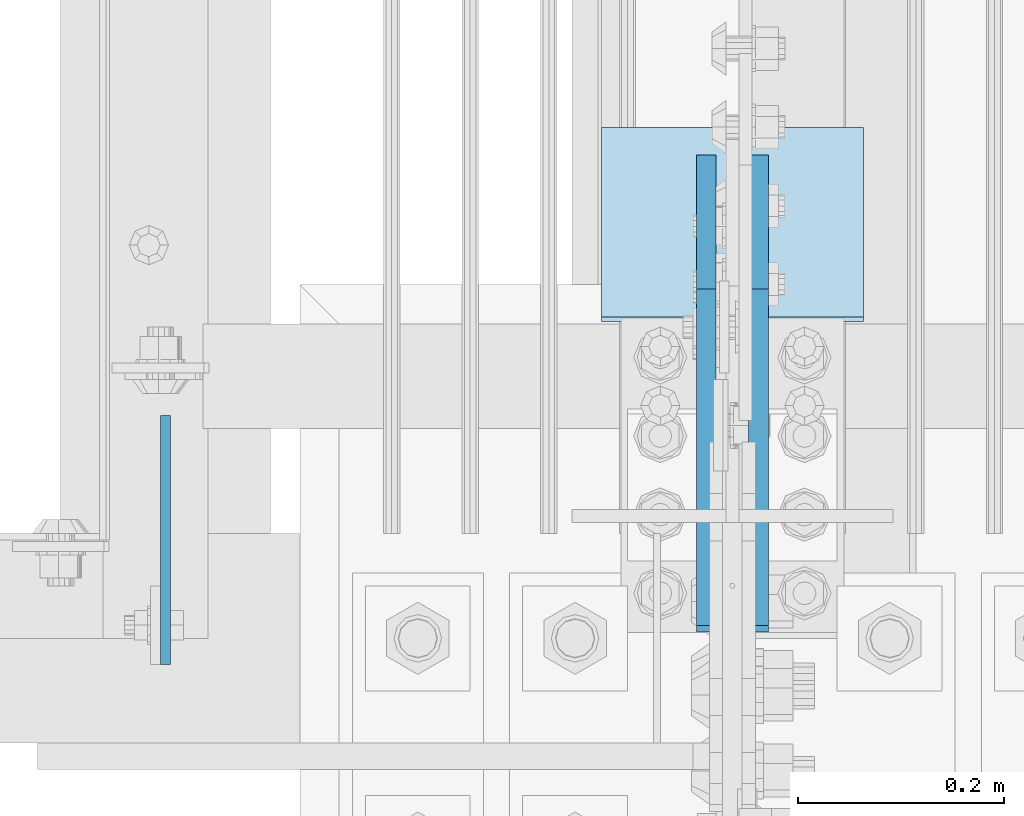
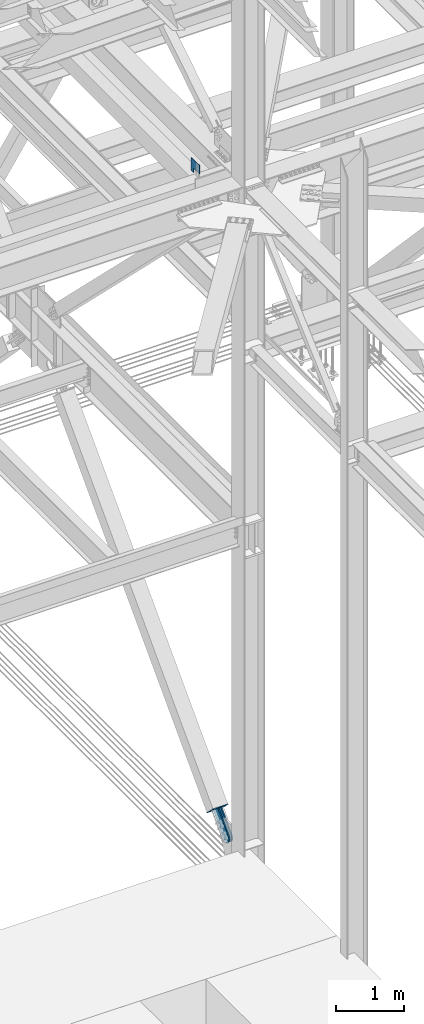
# One storey, part 3517 of 3843: 4 plates, 4 elements without a shape of their own.
"""IFC2X3 building model written with IfcOpenShell, lengths in millimetres."""

from ifc_helpers import new_model, si_unit, frame, origin_with_axes, place, context, subcontext, project, spatial, faceted_brep, material, type_object, element, aggregate, save


model = new_model("IFC2X3")

# Units and contexts
model_context = context("Model", 3, precision=1e-05, world=origin_with_axes())
body_context = subcontext(model_context, "Body", "Model", "MODEL_VIEW")
ifc_project = project(units=[si_unit("LENGTHUNIT", "METRE", prefix="MILLI"), si_unit("AREAUNIT", "SQUARE_METRE"), si_unit("VOLUMEUNIT", "CUBIC_METRE"), si_unit("MASSUNIT", "GRAM", prefix="KILO"), si_unit("TIMEUNIT", "SECOND"), si_unit("PLANEANGLEUNIT", "RADIAN"), si_unit("SOLIDANGLEUNIT", "STERADIAN"), si_unit("THERMODYNAMICTEMPERATUREUNIT", "DEGREE_CELSIUS"), si_unit("LUMINOUSINTENSITYUNIT", "LUMEN")], contexts=[model_context])

# Site, building, storey
site_placement = place(None, origin_with_axes())
site = spatial("IfcSite", under=ifc_project, at=site_placement, CompositionType="ELEMENT")
building_placement = place(site_placement, origin_with_axes())
building = spatial("IfcBuilding", under=site, at=building_placement, Name="Undefined", CompositionType="ELEMENT")
storey_placement = place(building_placement, origin_with_axes())
storey = spatial("IfcBuildingStorey", under=building, at=storey_placement, Name="Undefined", CompositionType="ELEMENT", Elevation=0.0)

# Assembly, plate
assembly_1_placement = place(storey_placement, origin_with_axes())
assembly_1 = element("IfcElementAssembly", 1, at=assembly_1_placement, inside=storey, Name="GIRT", AssemblyPlace="NOTDEFINED", PredefinedType="RIGID_FRAME")
ifc_material_1 = material(Name="STEEL/A572-50")
plate_type_1 = type_object("IfcPlateType", PredefinedType="NOTDEFINED")
plate_1_placement = place(assembly_1_placement, frame((76463.5254821973, 92938.6005071215, 42367.2), z_axis=(0.0, 0.0, 1.0), x_axis=(0.0, -1.0, 0.0)))
plate_1 = element("IfcPlate", 2, at=plate_1_placement, type_object=plate_type_1, material=ifc_material_1, Name="PLATE", context=body_context, shape_type="Brep", body=[
    faceted_brep([(0.0, -4.76249999999709, 0.0), (0.0, -4.76249999999709, 228.599999999999), (0.0, 4.76249999999709, 228.599999999999), (0.0, 4.76249999999709, 0.0), (241.300018310547, -4.76249999999709, 228.600006103516), (241.300018310547, 4.76249999999709, 228.600006103516), (241.300018310547, -4.76249999999709, 76.1999969482422), (241.300018310547, 4.76249999999709, 76.1999969482422), (76.1999893188477, -4.76249999999709, 76.1999969482422), (76.1999893188477, 4.76249999999709, 76.1999969482422), (76.2000000012922, -4.76250000000073, 7.27595761418343e-11), (76.2000000012922, 4.76250000000073, 7.27595761418343e-11)], [[[0, 1, 2, 3]], [[1, 4, 5, 2]], [[4, 6, 7, 5]], [[6, 8, 9, 7]], [[8, 10, 11, 9]], [[10, 0, 3, 11]], [[5, 7, 9, 11, 3, 2]], [[10, 8, 6, 4, 1, 0]]]),
])
aggregate(assembly_1, [plate_1])

assembly_2_placement = place(storey_placement, origin_with_axes())
assembly_2 = element("IfcElementAssembly", 3, at=assembly_2_placement, inside=storey, AssemblyPlace="NOTDEFINED", PredefinedType="RIGID_FRAME")
ifc_material_2 = material(Name="STEEL/A36")
plate_type_2 = type_object("IfcPlateType", PredefinedType="NOTDEFINED")
plate_2_placement = place(assembly_2_placement, frame((76987.4, 93142.5901441007, 30518.9655603602), z_axis=(0.0, -0.722239942286859, 0.691642585274702), x_axis=(0.0, 0.691642585274703, 0.722239942286858)))
plate_2 = element("IfcPlate", 4, at=plate_2_placement, type_object=plate_type_2, material=ifc_material_2, context=body_context, shape_type="Brep", body=[
    faceted_brep([(0.0, -9.52500000000146, 0.0), (-101.59999999866, -9.52499999999418, -7.01164927375794), (-101.59999999866, 9.52499999999418, -7.01164927375794), (0.0, 9.52500000000146, 0.0), (-364.729297655074, -9.52499999999418, -7.01164927444188), (-364.729297655074, 9.52499999999418, -7.01164927444188), (-401.787405121293, -9.52499999999418, 0.359666612348519), (-401.787405121293, 9.52499999999418, 0.359666612348519), (-433.203751657995, -9.52499999999418, 21.3513982502482), (-433.203751657995, 9.52499999999418, 21.3513982502482), (-454.195483294687, -9.52499999999418, 52.7677447877504), (-454.195483294687, 9.52499999999418, 52.7677447877504), (-461.566799180051, -9.52499999999418, 89.8258492000314), (-461.566799180051, 9.52499999999418, 89.8258492000314), (-454.195483292249, -9.52499999999418, 126.883956664562), (-454.195483292249, 9.52499999999418, 126.883956664562), (-433.203751654662, -9.52499999999418, 158.300303199998), (-433.203751654662, 9.52499999999418, 158.300303199998), (-401.787405118426, -9.52499999999418, 179.292034836384), (-401.787405118426, 9.52499999999418, 179.292034836384), (-364.729299177612, -9.52499999999418, 186.663350722738), (-364.729299177612, 9.52499999999418, 186.663350722738), (-101.5999999907, -9.52499999999418, 186.663350723451), (-101.5999999907, 9.52499999999418, 186.663350723451), (7.37782102078199e-09, -9.52499999999418, 179.651701450231), (7.37782102078199e-09, 9.52499999999418, 179.651701450231), (69.8500000062704, -9.52499999999418, 179.651701450392), (69.8500000062704, 9.52499999999418, 179.651701450392), (69.8499999979995, -9.52499999999418, -4.00177668780088e-10), (69.8499999979995, 9.52499999999418, -4.00177668780088e-10)], [[[0, 1, 2, 3]], [[1, 4, 5, 2]], [[4, 6, 7, 5]], [[6, 8, 9, 7]], [[8, 10, 11, 9]], [[10, 12, 13, 11]], [[12, 14, 15, 13]], [[14, 16, 17, 15]], [[16, 18, 19, 17]], [[18, 20, 21, 19]], [[20, 22, 23, 21]], [[22, 24, 25, 23]], [[24, 26, 27, 25]], [[26, 28, 29, 27]], [[28, 0, 3, 29]], [[5, 7, 9, 11, 13, 15, 17, 19, 21, 23, 25, 27, 29, 3, 2]], [[28, 26, 24, 22, 20, 18, 16, 14, 12, 10, 8, 6, 4, 1, 0]]]),
])
aggregate(assembly_2, [plate_2])

assembly_3_placement = place(storey_placement, origin_with_axes())
assembly_3 = element("IfcElementAssembly", 5, at=assembly_3_placement, inside=storey, AssemblyPlace="NOTDEFINED", PredefinedType="RIGID_FRAME")
plate_3_placement = place(assembly_3_placement, frame((77038.2, 93142.5901441007, 30518.9655603602), z_axis=(0.0, -0.722239942286859, 0.691642585274702), x_axis=(0.0, 0.691642585274703, 0.722239942286858)))
plate_3 = element("IfcPlate", 6, at=plate_3_placement, type_object=plate_type_2, material=ifc_material_2, context=body_context, shape_type="Brep", body=[
    faceted_brep([(0.0, -9.52500000000146, 0.0), (-101.59999999866, -9.52499999999418, -7.01164927375794), (-101.59999999866, 9.52499999999418, -7.01164927375794), (0.0, 9.52500000000146, 0.0), (-364.729297655074, -9.52499999999418, -7.01164927444188), (-364.729297655074, 9.52499999999418, -7.01164927444188), (-401.787405121293, -9.52499999999418, 0.359666612348519), (-401.787405121293, 9.52499999999418, 0.359666612348519), (-433.203751657995, -9.52499999999418, 21.3513982502482), (-433.203751657995, 9.52499999999418, 21.3513982502482), (-454.195483294687, -9.52499999999418, 52.7677447877504), (-454.195483294687, 9.52499999999418, 52.7677447877504), (-461.566799180051, -9.52499999999418, 89.8258492000314), (-461.566799180051, 9.52499999999418, 89.8258492000314), (-454.195483292249, -9.52499999999418, 126.883956664562), (-454.195483292249, 9.52499999999418, 126.883956664562), (-433.203751654662, -9.52499999999418, 158.300303199998), (-433.203751654662, 9.52499999999418, 158.300303199998), (-401.787405118426, -9.52499999999418, 179.292034836384), (-401.787405118426, 9.52499999999418, 179.292034836384), (-364.729299177612, -9.52499999999418, 186.663350722738), (-364.729299177612, 9.52499999999418, 186.663350722738), (-101.5999999907, -9.52499999999418, 186.663350723451), (-101.5999999907, 9.52499999999418, 186.663350723451), (7.37782102078199e-09, -9.52499999999418, 179.651701450231), (7.37782102078199e-09, 9.52499999999418, 179.651701450231), (69.8500000062704, -9.52499999999418, 179.651701450392), (69.8500000062704, 9.52499999999418, 179.651701450392), (69.8499999979995, -9.52499999999418, -4.00177668780088e-10), (69.8499999979995, 9.52499999999418, -4.00177668780088e-10)], [[[0, 1, 2, 3]], [[1, 4, 5, 2]], [[4, 6, 7, 5]], [[6, 8, 9, 7]], [[8, 10, 11, 9]], [[10, 12, 13, 11]], [[12, 14, 15, 13]], [[14, 16, 17, 15]], [[16, 18, 19, 17]], [[18, 20, 21, 19]], [[20, 22, 23, 21]], [[22, 24, 25, 23]], [[24, 26, 27, 25]], [[26, 28, 29, 27]], [[28, 0, 3, 29]], [[5, 7, 9, 11, 13, 15, 17, 19, 21, 23, 25, 27, 29, 3, 2]], [[28, 26, 24, 22, 20, 18, 16, 14, 12, 10, 8, 6, 4, 1, 0]]]),
])
aggregate(assembly_3, [plate_3])

assembly_4_placement = place(storey_placement, origin_with_axes())
assembly_4 = element("IfcElementAssembly", 7, at=assembly_4_placement, inside=storey, Name="Plate", AssemblyPlace="NOTDEFINED", PredefinedType="RIGID_FRAME")
plate_type_3 = type_object("IfcPlateType", PredefinedType="NOTDEFINED")
plate_4_placement = place(assembly_4_placement, frame((77139.8, 93215.5540688722, 30541.4096838118), z_axis=(0.0, -0.722239942286859, 0.691642585274702), x_axis=(-1.0, 0.0, 0.0)))
plate_4 = element("IfcPlate", 8, at=plate_4_placement, type_object=plate_type_3, material=ifc_material_2, Name="Plate", context=body_context, shape_type="Brep", body=[
    faceted_brep([(0.0, -3.17499999999927, 0.0), (0.0, -3.17499999965185, 254.000000005151), (0.0, 3.17500000035216, 254.000000005166), (0.0, 3.17499999999927, 0.0), (254.0, -3.17499999965185, 254.000000005151), (254.0, 3.17500000035216, 254.000000005166), (254.0, -3.17500000000291, 0.0), (254.0, 3.17499999999927, 1.45519152283669e-11)], [[[0, 1, 2, 3]], [[1, 4, 5, 2]], [[4, 6, 7, 5]], [[6, 0, 3, 7]], [[5, 7, 3, 2]], [[6, 4, 1, 0]]]),
])
aggregate(assembly_4, [plate_4])

save(model, "model.ifc")
